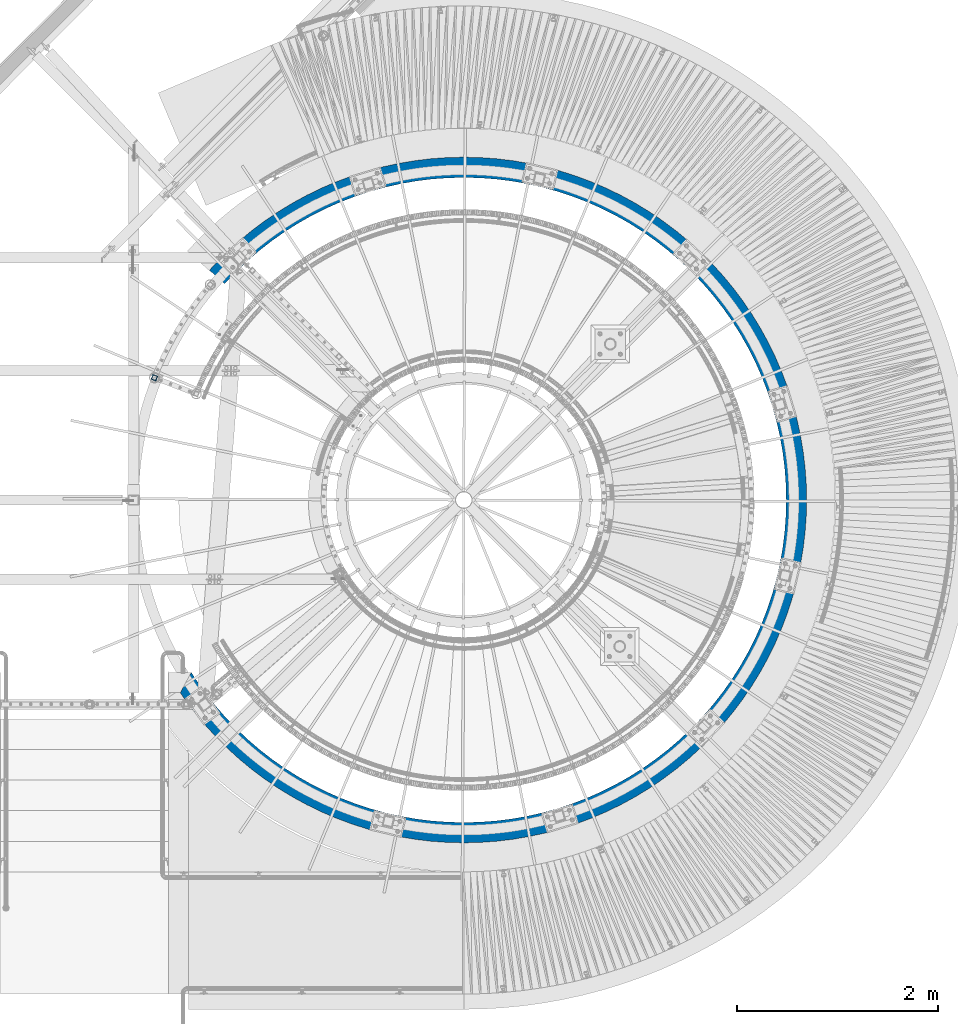
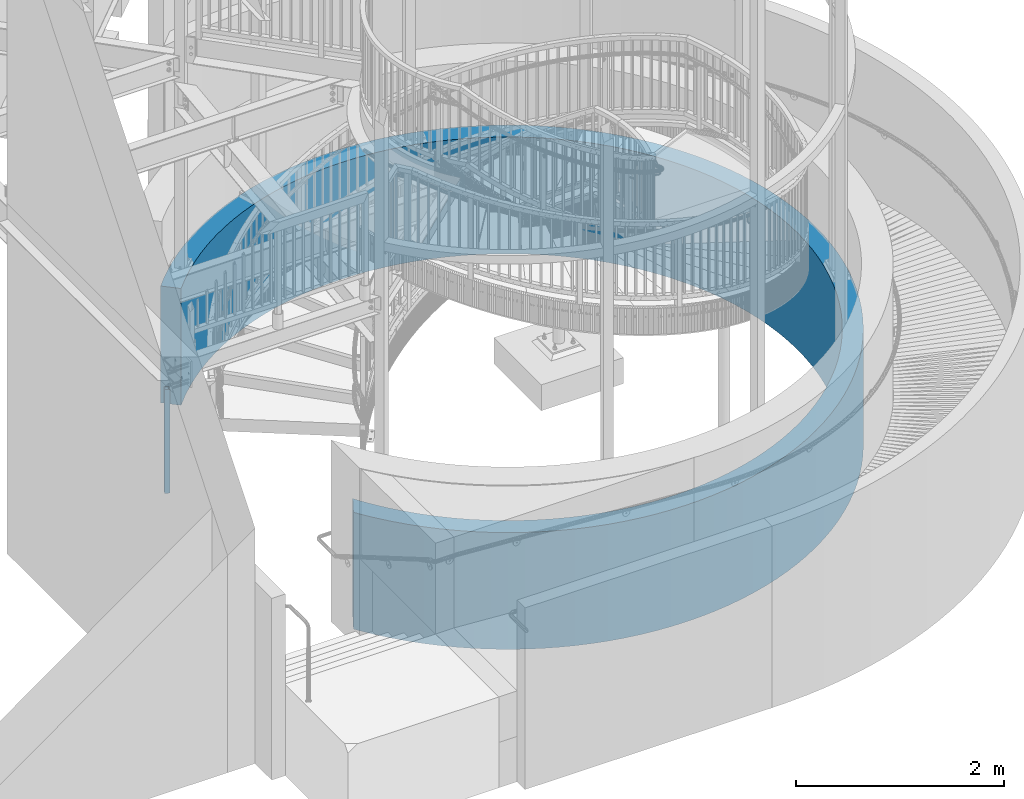
# One storey, part 133 of 975: 2 columns.
"""IFC2X3 building model written with IfcOpenShell, lengths in millimetres."""

from ifc_helpers import new_model, si_unit, frame, origin_with_axes, place, context, subcontext, project, spatial, faceted_brep, material, type_object, element, save


model = new_model("IFC2X3")

# Units and contexts
model_context = context("Model", 3, precision=1e-05, world=origin_with_axes())
body_context = subcontext(model_context, "Body", "Model", "MODEL_VIEW")
ifc_project = project(units=[si_unit("LENGTHUNIT", "METRE", prefix="MILLI"), si_unit("AREAUNIT", "SQUARE_METRE"), si_unit("VOLUMEUNIT", "CUBIC_METRE"), si_unit("MASSUNIT", "GRAM", prefix="KILO"), si_unit("TIMEUNIT", "SECOND"), si_unit("PLANEANGLEUNIT", "RADIAN"), si_unit("SOLIDANGLEUNIT", "STERADIAN"), si_unit("THERMODYNAMICTEMPERATUREUNIT", "DEGREE_CELSIUS"), si_unit("LUMINOUSINTENSITYUNIT", "LUMEN")], contexts=[model_context])

# Site, building, storey
site_placement = place(None, origin_with_axes())
site = spatial("IfcSite", under=ifc_project, at=site_placement, CompositionType="ELEMENT")
building_placement = place(site_placement, origin_with_axes())
building = spatial("IfcBuilding", under=site, at=building_placement, Name="Undefined", CompositionType="ELEMENT")
storey_placement = place(building_placement, origin_with_axes())
storey = spatial("IfcBuildingStorey", under=building, at=storey_placement, Name="Undefined", CompositionType="ELEMENT", Elevation=0.0)

# Columns
ifc_material_1 = material()
column_type_1 = type_object("IfcColumnType", Name="HSS2X2X.188_TUBES", PredefinedType="NOTDEFINED")
column_1_placement = place(storey_placement, frame((31648.9149123905, 4623.21435817273, -203.2), z_axis=(-0.929988356103301, 0.36758897904083, 0.0), x_axis=(0.0, 0.0, 1.0)))
element("IfcColumn", 1, at=column_1_placement, inside=storey, type_object=column_type_1, material=ifc_material_1, Name="HANDRAIL", ObjectType="HSS2X2X.188_TUBES", context=body_context, shape_type="Brep", body=[
    faceted_brep([(0.0, 20.6374999999753, -20.6375000000298), (0.0, -20.6375000000153, -20.6375000000153), (1219.2, -20.6374999999971, -20.6375000000298), (1219.2, 20.6374999999844, -20.6374999999716), (0.0, -20.6374999999825, 20.6375000000335), (1219.2, -20.6374999999898, 20.6374999999825), (0.0, 20.6375000000116, 20.6375000000189), (1219.2, 20.6374999999916, 20.6375000000407), (0.0, 25.3999999999724, -25.4000000000342), (0.0, 25.400000000016, 25.4000000000196), (1219.19999999993, 25.400000000016, 25.4000000000196), (1219.2, 25.3999999999814, -25.3999999999614), (0.0, -25.399999999976, 25.4000000000378), (1219.19999934962, -25.399999999976, 25.4000000000378), (0.0, -25.400000000016, -25.4000000000196), (1219.2, -25.399999999996, -25.4000000000378)], [[[0, 1, 2, 3]], [[1, 4, 5, 2]], [[4, 6, 7, 5]], [[6, 0, 3, 7]], [[8, 9, 10, 11]], [[9, 12, 13, 10]], [[12, 14, 15, 13]], [[14, 8, 11, 15]], [[13, 15, 11, 10], [5, 7, 3, 2]], [[14, 12, 9, 8], [6, 4, 1, 0]]]),
])
ifc_material_2 = material(Name="STEEL/Zero_Density")
column_type_2 = type_object("IfcColumnType", PredefinedType="NOTDEFINED")
column_2_placement = place(storey_placement, frame((34734.5, 3403.59999999999, -1.02318153949454e-12), z_axis=(0.0, 1.0, 0.0), x_axis=(0.0, 0.0, 1.0)))
element("IfcColumn", 2, at=column_2_placement, inside=storey, type_object=column_type_2, material=ifc_material_2, Name="WALL", context=body_context, shape_type="Brep", body=[
    faceted_brep([(1371.6, -2536.44157905321, 2291.88939873259), (-5.42101086242752e-20, -2536.44158720958, 2291.88938976323), (2.86308850465079e-05, -2386.29403404741, 2156.2183829727), (1371.6, -2386.29401758672, 2156.21838297135), (1371.6, -2383.10246661706, 2159.91827750059), (2.85925926453067e-05, -2383.10248307893, 2159.91827750059), (2.72865718446975e-05, -2274.24976503867, 2274.24986266076), (1371.6, -2274.24974857681, 2274.24986266076), (2.59148152999452e-05, -2159.9181798785, 2383.10258070102), (1371.6, -2159.91816341664, 2383.10258070102), (2.44806276927179e-05, -2040.38316240134, 2486.21419588924), (1371.6, -2040.38314593947, 2486.21419588924), (2.29874641065811e-05, -1915.93268293431, 2583.33630331291), (1371.6, -1915.93266647244, 2583.33630331291), (2.14389217033998e-05, -1786.86655358303, 2674.23492730837), (1371.6, -1786.86653712117, 2674.23492730837), (1.98387310574593e-05, -1653.49570595796, 2758.69108512862), (1371.6, -1653.4956894961, 2758.69108512862), (1.81907471681861e-05, -1516.14144211294, 2836.501314492), (1371.6, -1516.14142565108, 2836.501314492), (1.64989401731156e-05, -1375.13466050039, 2907.4781637406), (1371.6, -1375.13464403852, 2907.4781637406), (1.47673857834837e-05, -1230.81505880794, 2971.45064342774), (1371.6, -1230.81504234608, 2971.45064342774), (1.30002554654814e-05, -1083.53031559697, 3028.26463824652), (1371.6, -1083.53029913511, 3028.26463824652), (1.1201806390827e-05, -933.635252714506, 3077.78327830711), (1371.6, -933.635236252638, 3077.78327830711), (9.37637118086693e-06, -781.490980496281, 3119.88726886828), (1371.6, -781.490964034412, 3119.88726886828), (7.52834746891109e-06, -627.46402782033, 3154.4751777289), (1371.6, -627.464011358468, 3154.4751777289), (5.66218730594964e-06, -471.925459106831, 3181.46367958698), (1371.6, -471.925442644962, 3181.46367958698), (3.78238643527118e-06, -315.249980391367, 3200.78775677762), (1371.6, -315.249963929498, 3200.78775677762), (1.89347346182442e-06, -157.815036625325, 3212.40085590629), (1371.6, -157.815020163463, 3212.40085590629), (-1.05758831596761e-12, 9.76220908341929e-05, 3216.275), (1371.6, 0.000114083959488198, 3216.275), (-1.89347557700106e-06, 157.815231869507, 3212.40085590629), (1371.6, 157.815248331375, 3212.40085590629), (-3.78238855044781e-06, 315.250175635549, 3200.78775677762), (1371.6, 315.250192097417, 3200.78775677762), (-5.66218942112627e-06, 471.925654351013, 3181.46367958698), (1371.6, 471.925670812874, 3181.46367958698), (-7.52834958408772e-06, 627.464223064511, 3154.4751777289), (1371.6, 627.46423952638, 3154.4751777289), (-9.37637329604345e-06, 781.491175740462, 3119.88726886828), (1371.6, 781.491192202324, 3119.88726886828), (-1.12018085060036e-05, 933.635447958688, 3077.78327830711), (1371.6, 933.635464420549, 3077.78327830711), (-1.3000257580658e-05, 1083.53051084116, 3028.26463824652), (1371.6, 1083.53052730302, 3028.26463824652), (-1.47673878986603e-05, 1230.81525405212, 2971.45064342774), (1371.6, 1230.81527051399, 2971.45064342774), (-1.64989422882922e-05, 1375.13485574457, 2907.4781637406), (1371.6, 1375.13487220644, 2907.4781637406), (-1.81907492833627e-05, 1516.14163735713, 2836.50131449201), (1371.6, 1516.141653819, 2836.50131449201), (-1.98387331726359e-05, 1653.49590120214, 2758.69108512862), (1371.6, 1653.49591766401, 2758.69108512862), (-2.14389238185764e-05, 1786.86674882721, 2674.23492730837), (1371.6, 1786.86676528908, 2674.23492730837), (-2.29874662217577e-05, 1915.93287817849, 2583.33630331291), (1371.6, 1915.93289464035, 2583.33630331291), (-2.44806298078945e-05, 2040.38335764552, 2486.21419588924), (1371.6, 2040.38337410738, 2486.21419588924), (-2.59148174151219e-05, 2159.91837512269, 2383.10258070102), (1371.6, 2159.91839158455, 2383.10258070102), (-2.72865739598742e-05, 2274.24996028285, 2274.24986266076), (1371.6, 2274.24997674472, 2274.24986266076), (-2.85925947604833e-05, 2383.10267832311, 2159.91827750059), (1371.6, 2383.10269478498, 2159.91827750059), (-2.98297334984468e-05, 2486.21429351133, 2040.38326002343), (1371.6, 2486.21430997319, 2040.38326002343), (-3.09950097981842e-05, 2583.336400935, 1915.9327805564), (1371.6, 2583.33641739687, 1915.9327805564), (-3.20856164070234e-05, 2674.23502493046, 1786.86665120512), (1371.6, 2674.23504139233, 1786.86665120512), (-3.30989259581179e-05, 2758.69118275071, 1653.49580358005), (1371.6, 2758.69119921258, 1653.49580358005), (-3.40324973000035e-05, 2836.5014121141, 1516.14153973504), (1371.6, 2836.50142857596, 1516.14153973504), (-3.48840813775466e-05, 2907.4782613627, 1375.13475812248), (1371.6, 2907.47827782456, 1375.13475812248), (-3.56516266501143e-05, 2971.45074104983, 1230.81515643003), (1371.6, 2971.45075751169, 1230.81515643003), (-3.6333284033916e-05, 3028.26473586861, 1083.53041321906), (1371.6, 3028.26475233048, 1083.53041321906), (-3.69274113566081e-05, 3077.7833759292, 933.635350336596), (1371.6, 3077.78339239107, 933.635350336596), (-3.74325773134306e-05, 3119.88736649037, 781.491078118371), (1371.6, 3119.88738295224, 781.491078118371), (-3.78475649153464e-05, 3154.47527535099, 627.464125442424), (1371.6, 3154.47529181286, 627.464125442424), (-3.81713744208737e-05, 3181.46377720906, 471.925556728919), (1371.6, 3181.46379367093, 471.925556728919), (-3.84032257445515e-05, 3200.78785439971, 315.250078013458), (1371.6, 3200.78787086158, 315.250078013458), (-3.85425603362332e-05, 3212.40095352838, 157.815134247416), (1371.6, 3212.40096999025, 157.815134247416), (-3.85890425266831e-05, 3216.27509762209, 4.54747350886464e-13), (1371.6, 3216.27511408396, 4.54747350886464e-13), (-3.85425603362332e-05, 3212.40095352838, -157.815134247415), (1371.6, 3212.40096999025, -157.815134247415), (-3.84032257445515e-05, 3200.78785439971, -315.250078013457), (1371.6, 3200.78787086158, -315.250078013457), (-3.81713744208737e-05, 3181.46377720906, -471.925556728918), (1371.6, 3181.46379367093, -471.925556728918), (-3.78475649153464e-05, 3154.47527535099, -627.464125442423), (1371.6, 3154.47529181286, -627.464125442423), (-3.74325773134306e-05, 3119.88736649037, -781.49107811837), (1371.6, 3119.88738295224, -781.49107811837), (-3.69274113566081e-05, 3077.7833759292, -933.635350336595), (1371.6, 3077.78339239107, -933.635350336595), (-3.6333284033916e-05, 3028.26473586861, -1083.53041321906), (1371.6, 3028.26475233048, -1083.53041321906), (-3.56516266501143e-05, 2971.45074104983, -1230.81515643003), (1371.6, 2971.45075751169, -1230.81515643003), (-3.48840813775466e-05, 2907.4782613627, -1375.13475812248), (1371.6, 2907.47827782456, -1375.13475812248), (-3.40324973000035e-05, 2836.5014121141, -1516.14153973504), (1371.6, 2836.50142857596, -1516.14153973504), (-3.30989259581179e-05, 2758.69118275071, -1653.49580358005), (1371.6, 2758.69119921258, -1653.49580358005), (-3.20856164070234e-05, 2674.23502493046, -1786.86665120512), (1371.6, 2674.23504139233, -1786.86665120512), (-3.09950097981842e-05, 2583.336400935, -1915.9327805564), (1371.6, 2583.33641739687, -1915.9327805564), (-2.98297334984468e-05, 2486.21429351133, -2040.38326002343), (1371.6, 2486.2143099732, -2040.38326002343), (-2.85925947604833e-05, 2383.10267832311, -2159.91827750059), (1371.6, 2383.10269478498, -2159.91827750059), (-2.72865739598742e-05, 2274.24996028285, -2274.24986266076), (1371.6, 2274.24997674472, -2274.24986266076), (-2.59148174151219e-05, 2159.91837512269, -2383.10258070102), (1371.6, 2159.91839158455, -2383.10258070102), (-2.44806298078945e-05, 2040.38335764552, -2486.21419588924), (1371.6, 2040.38337410739, -2486.21419588924), (-2.29874662217577e-05, 1915.93287817849, -2583.33630331291), (1371.6, 1915.93289464035, -2583.33630331291), (-2.14389238185764e-05, 1786.86674882721, -2674.23492730837), (1371.6, 1786.86676528908, -2674.23492730837), (-1.98387331726359e-05, 1653.49590120214, -2758.69108512862), (1371.6, 1653.49591766401, -2758.69108512862), (-1.81907492833627e-05, 1516.14163735713, -2836.50131449201), (1371.6, 1516.141653819, -2836.50131449201), (-1.64989422882922e-05, 1375.13485574457, -2907.4781637406), (1371.6, 1375.13487220644, -2907.4781637406), (-1.47673878986603e-05, 1230.81525405212, -2971.45064342774), (1371.6, 1230.81527051399, -2971.45064342774), (-1.3000257580658e-05, 1083.53051084116, -3028.26463824652), (1371.6, 1083.53052730302, -3028.26463824652), (-1.12018085060036e-05, 933.635447958688, -3077.78327830711), (1371.6, 933.635464420549, -3077.78327830711), (-9.37637329604345e-06, 781.491175740462, -3119.88726886828), (1371.6, 781.491192202324, -3119.88726886828), (-7.52834958408778e-06, 627.464223064519, -3154.4751777289), (1371.6, 627.46423952638, -3154.4751777289), (-5.66218942112627e-06, 471.925654351013, -3181.46367958698), (1371.6, 471.925670812874, -3181.46367958698), (-3.78238855044781e-06, 315.250175635549, -3200.78775677762), (1371.6, 315.25019209741, -3200.78775677762), (-1.89347557700106e-06, 157.815231869507, -3212.40085590629), (1371.6, 157.815248331375, -3212.40085590629), (-1.05758831596761e-12, 9.76220908341929e-05, -3216.275), (1371.6, 0.000114083959488198, -3216.275), (1.89347346182442e-06, -157.815036625325, -3212.40085590629), (1371.6, -157.815020163456, -3212.40085590629), (3.78238643527118e-06, -315.249980391367, -3200.78775677762), (1371.6, -315.249963929498, -3200.78775677762), (5.66218730594964e-06, -471.925459106831, -3181.46367958698), (1371.6, -471.925442644962, -3181.46367958698), (7.52834746891109e-06, -627.46402782033, -3154.4751777289), (1371.6, -627.464011358468, -3154.4751777289), (9.37637118086687e-06, -781.490980496281, -3119.88726886828), (1371.6, -781.490964034412, -3119.88726886828), (1.1201806390827e-05, -933.635252714506, -3077.78327830711), (1371.6, -933.635236252638, -3077.78327830711), (1.30002554654814e-05, -1083.53031559697, -3028.26463824652), (1371.6, -1083.53029913511, -3028.26463824652), (1.47673857834837e-05, -1230.81505880794, -2971.45064342774), (1371.6, -1230.81504234608, -2971.45064342774), (1.64989401731156e-05, -1375.13466050039, -2907.4781637406), (1371.6, -1375.13464403852, -2907.4781637406), (1.81907471681861e-05, -1516.14144211294, -2836.50131449201), (1371.6, -1516.14142565108, -2836.50131449201), (1.98387310574593e-05, -1653.49570595796, -2758.69108512863), (1371.6, -1653.4956894961, -2758.69108512863), (2.14389217033998e-05, -1786.86655358303, -2674.23492730837), (1371.6, -1786.86653712116, -2674.23492730837), (2.29874641065811e-05, -1915.93268293431, -2583.33630331291), (1371.6, -1915.93266647244, -2583.33630331291), (2.44806276927179e-05, -2040.38316240134, -2486.21419588924), (1371.6, -2040.38314593947, -2486.21419588924), (2.59148152999452e-05, -2159.9181798785, -2383.10258070102), (1371.6, -2159.91816341664, -2383.10258070102), (2.72865718446975e-05, -2274.24976503867, -2274.24986266076), (1371.6, -2274.24974857681, -2274.24986266076), (2.85925926453067e-05, -2383.10248307893, -2159.9182775006), (1371.6, -2383.10246661706, -2159.9182775006), (2.98297313832701e-05, -2486.21409826714, -2040.38326002343), (1371.6, -2486.21408180528, -2040.38326002343), (3.09950076830076e-05, -2583.33620569082, -1915.9327805564), (1371.6, -2583.33618922895, -1915.9327805564), (3.20856142918468e-05, -2674.23482968628, -1786.86665120512), (1371.6, -2674.23481322441, -1786.86665120512), (3.26075235737852e-05, -2717.73432363227, -1718.17344364546), (1371.6, -2717.73430717184, -1718.17344364319), (-1.0842021724855e-19, -2827.3831652323, -1921.49268502268), (1371.6, -2827.38315607086, -1921.49269855475), (-1.62630325872826e-19, -2785.42210363731, -1983.49010085597), (1371.6, -2785.42210363465, -1983.49010085597), (-1.0842021724855e-19, -2687.88890614558, -2113.77919940671), (1371.6, -2687.88890614292, -2113.77919940671), (-1.0842021724855e-19, -2584.26677576502, -2239.27990820756), (1371.6, -2584.26677576235, -2239.27990820756), (-1.0842021724855e-19, -2474.79044994933, -2359.7079277878), (1371.6, -2474.79044994666, -2359.7079277878), (-1.62630325872826e-19, -2359.70792778779, -2474.79044994934), (1371.6, -2359.70792778512, -2474.79044994934), (-1.0842021724855e-19, -2239.27990820754, -2584.26677576503), (1371.6, -2239.27990820488, -2584.26677576503), (-1.0842021724855e-19, -2113.7791994067, -2687.88890614559), (1371.6, -2113.77919940403, -2687.88890614559), (-1.0842021724855e-19, -1983.49010085596, -2785.42210363732), (1371.6, -1983.4901008533, -2785.42210363732), (-1.62630325872826e-19, -1848.70775926897, -2876.6454241779), (1371.6, -1848.7077592663, -2876.6454241779), (-1.62630325872826e-19, -1709.73749999999, -2961.35221760579), (1371.6, -1709.73749999733, -2961.35221760579), (-1.0842021724855e-19, -1566.89413538383, -3039.35059578929), (1371.6, -1566.89413538116, -3039.35059578929), (-1.0842021724855e-19, -1420.50125158462, -3110.46386731489), (1371.6, -1420.50125158195, -3110.46386731489), (-1.0842021724855e-19, -1270.89047556909, -3174.53093775014), (1371.6, -1270.89047556642, -3174.53093775014), (-1.0842021724855e-19, -1118.40072386483, -3231.40667457434), (1371.6, -1118.40072386216, -3231.40667457434), (-1.0842021724855e-19, -963.377434805341, -3280.96223595043), (1371.6, -963.377434802671, -3280.96223595043), (-5.42101086242752e-20, -806.17178600109, -3323.08536259314), (1371.6, -806.17178599842, -3323.08536259314), (-1.0842021724855e-19, -647.139898809306, -3357.68063207239), (1371.6, -647.139898806636, -3357.68063207239), (-1.0842021724855e-19, -486.642031604533, -3384.6696749758), (1371.6, -486.642031601863, -3384.6696749758), (-1.0842021724855e-19, -325.04176367756, -3403.9913524406), (1371.6, -325.041763674897, -3403.9913524406), (-1.0842021724855e-19, -162.705171611386, -3415.60189465282), (1371.6, -162.705171608715, -3415.60189465282), (-1.0842021724855e-19, 7.27595761418343e-12, -3419.475), (1371.6, 2.6775524020195e-09, -3419.475), (-1.0842021724855e-19, 162.7051716114, -3415.60189465282), (1371.6, 162.70517161407, -3415.60189465282), (-1.62630325872826e-19, 325.041763677582, -3403.9913524406), (1371.6, 325.041763680245, -3403.9913524406), (-5.42101086242752e-20, 486.642031604548, -3384.6696749758), (1371.6, 486.642031607218, -3384.6696749758), (-1.0842021724855e-19, 647.139898809321, -3357.68063207239), (1371.6, 647.139898811991, -3357.68063207239), (-1.0842021724855e-19, 806.171786001105, -3323.08536259314), (1371.6, 806.171786003775, -3323.08536259314), (-1.0842021724855e-19, 963.377434805356, -3280.96223595043), (1371.6, 963.377434808026, -3280.96223595043), (-1.0842021724855e-19, 1118.40072386485, -3231.40667457434), (1371.6, 1118.40072386752, -3231.40667457434), (-5.42101086242752e-20, 1270.8904755691, -3174.53093775013), (1371.6, 1270.89047557177, -3174.53093775013), (-1.0842021724855e-19, 1420.50125158463, -3110.46386731489), (1371.6, 1420.5012515873, -3110.46386731489), (-1.0842021724855e-19, 1566.89413538385, -3039.35059578929), (1371.6, 1566.89413538651, -3039.35059578929), (-1.0842021724855e-19, 1709.73750000001, -2961.35221760579), (1371.6, 1709.73750000267, -2961.35221760579), (-1.0842021724855e-19, 1848.70775926899, -2876.6454241779), (1371.6, 1848.70775927166, -2876.6454241779), (-1.62630325872826e-19, 1983.49010085598, -2785.42210363732), (1371.6, 1983.49010085865, -2785.42210363732), (-5.42101086242752e-20, 2113.77919940671, -2687.88890614559), (1371.6, 2113.77919940938, -2687.88890614559), (-1.0842021724855e-19, 2239.27990820756, -2584.26677576503), (1371.6, 2239.27990821023, -2584.26677576503), (-5.42101086242752e-20, 2359.7079277878, -2474.79044994933), (1371.6, 2359.70792779047, -2474.79044994933), (-1.62630325872826e-19, 2474.79044994935, -2359.70792778779), (1371.6, 2474.79044995201, -2359.70792778779), (-5.42101086242752e-20, 2584.26677576503, -2239.27990820755), (1371.6, 2584.2667757677, -2239.27990820755), (-1.0842021724855e-19, 2687.8889061456, -2113.7791994067), (1371.6, 2687.88890614827, -2113.7791994067), (-5.42101086242752e-20, 2785.42210363733, -1983.49010085597), (1371.6, 2785.42210364, -1983.49010085597), (-1.0842021724855e-19, 2876.64542417791, -1848.70775926898), (1371.6, 2876.64542418058, -1848.70775926898), (-1.0842021724855e-19, 2961.3522176058, -1709.7375), (1371.6, 2961.35221760847, -1709.7375), (-1.0842021724855e-19, 3039.3505957893, -1566.89413538384), (1371.6, 3039.35059579197, -1566.89413538384), (-1.62630325872826e-19, 3110.4638673149, -1420.50125158462), (1371.6, 3110.46386731757, -1420.50125158462), (-5.42101086242752e-20, 3174.53093775014, -1270.8904755691), (1371.6, 3174.53093775281, -1270.8904755691), (-5.42101086242752e-20, 3231.40667457435, -1118.40072386484), (1371.6, 3231.40667457702, -1118.40072386484), (-1.0842021724855e-19, 3280.96223595044, -963.377434805347), (1371.6, 3280.96223595311, -963.377434805347), (-1.0842021724855e-19, 3323.08536259315, -806.171786001098), (1371.6, 3323.08536259582, -806.171786001098), (-1.0842021724855e-19, 3357.6806320724, -647.139898809312), (1371.6, 3357.68063207507, -647.139898809312), (-1.0842021724855e-19, 3384.66967497581, -486.642031604541), (1371.6, 3384.66967497848, -486.642031604541), (-1.0842021724855e-19, 3403.99135244061, -325.04176367757), (1371.6, 3403.99135244327, -325.04176367757), (-5.42101086242752e-20, 3415.60189465282, -162.70517161139), (1371.6, 3415.60189465549, -162.70517161139), (-1.0842021724855e-19, 3419.47500000001, 4.54747350886464e-13), (1371.6, 3419.47500000268, 4.54747350886464e-13), (-5.42101086242752e-20, 3415.60189465282, 162.705171611392), (1371.6, 3415.60189465549, 162.705171611392), (-1.0842021724855e-19, 3403.99135244061, 325.041763677571), (1371.6, 3403.99135244327, 325.041763677571), (-1.0842021724855e-19, 3384.66967497581, 486.642031604542), (1371.6, 3384.66967497848, 486.642031604542), (-1.0842021724855e-19, 3357.6806320724, 647.139898809315), (1371.6, 3357.68063207507, 647.139898809315), (-1.0842021724855e-19, 3323.08536259315, 806.171786001099), (1371.6, 3323.08536259582, 806.171786001099), (-1.0842021724855e-19, 3280.96223595044, 963.377434805349), (1371.6, 3280.96223595311, 963.377434805349), (-5.42101086242752e-20, 3231.40667457435, 1118.40072386484), (1371.6, 3231.40667457702, 1118.40072386484), (-5.42101086242752e-20, 3174.53093775014, 1270.8904755691), (1371.6, 3174.53093775281, 1270.8904755691), (-1.62630325872826e-19, 3110.4638673149, 1420.50125158463), (1371.6, 3110.46386731757, 1420.50125158463), (-1.0842021724855e-19, 3039.3505957893, 1566.89413538384), (1371.6, 3039.35059579197, 1566.89413538384), (-1.62630325872826e-19, 2961.3522176058, 1709.7375), (1371.6, 2961.35221760847, 1709.7375), (-1.62630325872826e-19, 2876.64542417791, 1848.70775926898), (1371.6, 2876.64542418058, 1848.70775926898), (-5.42101086242752e-20, 2785.42210363733, 1983.49010085597), (1371.6, 2785.42210364, 1983.49010085597), (-1.0842021724855e-19, 2687.8889061456, 2113.7791994067), (1371.6, 2687.88890614827, 2113.7791994067), (-5.42101086242752e-20, 2584.26677576503, 2239.27990820755), (1371.6, 2584.2667757677, 2239.27990820755), (-1.62630325872826e-19, 2474.79044994935, 2359.70792778779), (1371.6, 2474.79044995201, 2359.70792778779), (-5.42101086242752e-20, 2359.7079277878, 2474.79044994934), (1371.6, 2359.70792779047, 2474.79044994934), (-1.0842021724855e-19, 2239.27990820756, 2584.26677576503), (1371.6, 2239.27990821023, 2584.26677576503), (-5.42101086242752e-20, 2113.77919940671, 2687.88890614559), (1371.6, 2113.77919940938, 2687.88890614559), (-1.62630325872826e-19, 1983.49010085598, 2785.42210363732), (1371.6, 1983.49010085865, 2785.42210363732), (-1.62630325872826e-19, 1848.70775926899, 2876.6454241779), (1371.6, 1848.70775927165, 2876.6454241779), (-5.42101086242752e-20, 1709.7375, 2961.35221760579), (1371.6, 1709.73750000267, 2961.35221760579), (-1.0842021724855e-19, 1566.89413538385, 3039.35059578929), (1371.6, 1566.89413538651, 3039.35059578929), (-1.0842021724855e-19, 1420.50125158463, 3110.46386731489), (1371.6, 1420.5012515873, 3110.46386731489), (-1.0842021724855e-19, 1270.8904755691, 3174.53093775013), (1371.6, 1270.89047557177, 3174.53093775013), (-1.0842021724855e-19, 1118.40072386485, 3231.40667457434), (1371.6, 1118.40072386751, 3231.40667457434), (-1.0842021724855e-19, 963.377434805356, 3280.96223595043), (1371.6, 963.377434808019, 3280.96223595043), (-1.0842021724855e-19, 806.171786001105, 3323.08536259314), (1371.6, 806.171786003775, 3323.08536259314), (-1.0842021724855e-19, 647.139898809321, 3357.68063207239), (1371.6, 647.139898811991, 3357.68063207239), (-5.42101086242752e-20, 486.642031604548, 3384.6696749758), (1371.6, 486.642031607218, 3384.6696749758), (-5.42101086242752e-20, 325.041763677575, 3403.9913524406), (1371.6, 325.041763680245, 3403.9913524406), (-1.0842021724855e-19, 162.7051716114, 3415.60189465282), (1371.6, 162.705171614063, 3415.60189465282), (-1.0842021724855e-19, 7.27595761418343e-12, 3419.475), (1371.6, 2.6775524020195e-09, 3419.475), (-1.0842021724855e-19, -162.705171611386, 3415.60189465282), (1371.6, -162.705171608715, 3415.60189465282), (-1.62630325872826e-19, -325.04176367756, 3403.9913524406), (1371.6, -325.041763674897, 3403.9913524406), (-1.62630325872826e-19, -486.642031604533, 3384.6696749758), (1371.6, -486.64203160187, 3384.6696749758), (-1.0842021724855e-19, -647.139898809306, 3357.68063207239), (1371.6, -647.139898806636, 3357.68063207239), (-1.0842021724855e-19, -806.17178600109, 3323.08536259314), (1371.6, -806.171785998427, 3323.08536259314), (-1.0842021724855e-19, -963.377434805341, 3280.96223595043), (1371.6, -963.377434802671, 3280.96223595043), (-1.0842021724855e-19, -1118.40072386483, 3231.40667457434), (1371.6, -1118.40072386216, 3231.40667457434), (-1.62630325872826e-19, -1270.89047556909, 3174.53093775013), (1371.6, -1270.89047556643, 3174.53093775013), (-1.0842021724855e-19, -1420.50125158462, 3110.46386731489), (1371.6, -1420.50125158195, 3110.46386731489), (-1.0842021724855e-19, -1566.89413538383, 3039.35059578929), (1371.6, -1566.89413538116, 3039.35059578929), (-1.0842021724855e-19, -1709.7375, 2961.35221760579), (1371.6, -1709.73749999733, 2961.35221760579), (-5.42101086242752e-20, -1848.70775926897, 2876.6454241779), (1371.6, -1848.7077592663, 2876.6454241779), (-1.0842021724855e-19, -1983.49010085596, 2785.42210363732), (1371.6, -1983.4901008533, 2785.42210363732), (-1.0842021724855e-19, -2113.7791994067, 2687.88890614559), (1371.6, -2113.77919940403, 2687.88890614559), (-1.0842021724855e-19, -2239.27990820755, 2584.26677576503), (1371.6, -2239.27990820488, 2584.26677576503), (-1.0842021724855e-19, -2359.70792778779, 2474.79044994933), (1371.6, -2359.70792778512, 2474.79044994933), (-1.0842021724855e-19, -2474.79044994933, 2359.70792778779), (1371.6, -2474.79044994666, 2359.70792778779)], [[[0, 1, 2, 3]], [[4, 5, 6, 7]], [[7, 6, 8, 9]], [[9, 8, 10, 11]], [[11, 10, 12, 13]], [[13, 12, 14, 15]], [[15, 14, 16, 17]], [[17, 16, 18, 19]], [[19, 18, 20, 21]], [[21, 20, 22, 23]], [[23, 22, 24, 25]], [[25, 24, 26, 27]], [[27, 26, 28, 29]], [[29, 28, 30, 31]], [[31, 30, 32, 33]], [[33, 32, 34, 35]], [[35, 34, 36, 37]], [[37, 36, 38, 39]], [[39, 38, 40, 41]], [[41, 40, 42, 43]], [[43, 42, 44, 45]], [[45, 44, 46, 47]], [[47, 46, 48, 49]], [[49, 48, 50, 51]], [[51, 50, 52, 53]], [[53, 52, 54, 55]], [[55, 54, 56, 57]], [[57, 56, 58, 59]], [[59, 58, 60, 61]], [[61, 60, 62, 63]], [[63, 62, 64, 65]], [[65, 64, 66, 67]], [[67, 66, 68, 69]], [[69, 68, 70, 71]], [[71, 70, 72, 73]], [[73, 72, 74, 75]], [[75, 74, 76, 77]], [[77, 76, 78, 79]], [[79, 78, 80, 81]], [[81, 80, 82, 83]], [[83, 82, 84, 85]], [[85, 84, 86, 87]], [[87, 86, 88, 89]], [[89, 88, 90, 91]], [[91, 90, 92, 93]], [[93, 92, 94, 95]], [[95, 94, 96, 97]], [[97, 96, 98, 99]], [[99, 98, 100, 101]], [[101, 100, 102, 103]], [[103, 102, 104, 105]], [[105, 104, 106, 107]], [[107, 106, 108, 109]], [[109, 108, 110, 111]], [[111, 110, 112, 113]], [[113, 112, 114, 115]], [[115, 114, 116, 117]], [[117, 116, 118, 119]], [[119, 118, 120, 121]], [[121, 120, 122, 123]], [[123, 122, 124, 125]], [[125, 124, 126, 127]], [[127, 126, 128, 129]], [[129, 128, 130, 131]], [[131, 130, 132, 133]], [[133, 132, 134, 135]], [[135, 134, 136, 137]], [[137, 136, 138, 139]], [[139, 138, 140, 141]], [[141, 140, 142, 143]], [[143, 142, 144, 145]], [[145, 144, 146, 147]], [[147, 146, 148, 149]], [[149, 148, 150, 151]], [[151, 150, 152, 153]], [[153, 152, 154, 155]], [[155, 154, 156, 157]], [[157, 156, 158, 159]], [[159, 158, 160, 161]], [[161, 160, 162, 163]], [[163, 162, 164, 165]], [[165, 164, 166, 167]], [[167, 166, 168, 169]], [[169, 168, 170, 171]], [[171, 170, 172, 173]], [[173, 172, 174, 175]], [[175, 174, 176, 177]], [[177, 176, 178, 179]], [[179, 178, 180, 181]], [[181, 180, 182, 183]], [[183, 182, 184, 185]], [[185, 184, 186, 187]], [[187, 186, 188, 189]], [[189, 188, 190, 191]], [[191, 190, 192, 193]], [[193, 192, 194, 195]], [[195, 194, 196, 197]], [[197, 196, 198, 199]], [[199, 198, 200, 201]], [[201, 200, 202, 203]], [[203, 202, 204, 205]], [[205, 204, 206, 207]], [[207, 206, 208, 209]], [[209, 208, 210, 211]], [[212, 213, 211, 210]], [[212, 214, 215, 213]], [[214, 216, 217, 215]], [[216, 218, 219, 217]], [[218, 220, 221, 219]], [[220, 222, 223, 221]], [[222, 224, 225, 223]], [[224, 226, 227, 225]], [[226, 228, 229, 227]], [[228, 230, 231, 229]], [[230, 232, 233, 231]], [[232, 234, 235, 233]], [[234, 236, 237, 235]], [[236, 238, 239, 237]], [[238, 240, 241, 239]], [[240, 242, 243, 241]], [[242, 244, 245, 243]], [[244, 246, 247, 245]], [[246, 248, 249, 247]], [[248, 250, 251, 249]], [[250, 252, 253, 251]], [[252, 254, 255, 253]], [[254, 256, 257, 255]], [[256, 258, 259, 257]], [[258, 260, 261, 259]], [[260, 262, 263, 261]], [[262, 264, 265, 263]], [[264, 266, 267, 265]], [[266, 268, 269, 267]], [[268, 270, 271, 269]], [[270, 272, 273, 271]], [[272, 274, 275, 273]], [[274, 276, 277, 275]], [[276, 278, 279, 277]], [[278, 280, 281, 279]], [[280, 282, 283, 281]], [[282, 284, 285, 283]], [[284, 286, 287, 285]], [[286, 288, 289, 287]], [[288, 290, 291, 289]], [[290, 292, 293, 291]], [[292, 294, 295, 293]], [[294, 296, 297, 295]], [[296, 298, 299, 297]], [[298, 300, 301, 299]], [[300, 302, 303, 301]], [[302, 304, 305, 303]], [[304, 306, 307, 305]], [[306, 308, 309, 307]], [[308, 310, 311, 309]], [[310, 312, 313, 311]], [[312, 314, 315, 313]], [[314, 316, 317, 315]], [[316, 318, 319, 317]], [[318, 320, 321, 319]], [[320, 322, 323, 321]], [[322, 324, 325, 323]], [[324, 326, 327, 325]], [[326, 328, 329, 327]], [[328, 330, 331, 329]], [[330, 332, 333, 331]], [[332, 334, 335, 333]], [[334, 336, 337, 335]], [[336, 338, 339, 337]], [[338, 340, 341, 339]], [[340, 342, 343, 341]], [[342, 344, 345, 343]], [[344, 346, 347, 345]], [[346, 348, 349, 347]], [[348, 350, 351, 349]], [[350, 352, 353, 351]], [[352, 354, 355, 353]], [[354, 356, 357, 355]], [[356, 358, 359, 357]], [[358, 360, 361, 359]], [[360, 362, 363, 361]], [[362, 364, 365, 363]], [[364, 366, 367, 365]], [[366, 368, 369, 367]], [[368, 370, 371, 369]], [[370, 372, 373, 371]], [[372, 374, 375, 373]], [[374, 376, 377, 375]], [[376, 378, 379, 377]], [[378, 380, 381, 379]], [[380, 382, 383, 381]], [[382, 384, 385, 383]], [[384, 386, 387, 385]], [[386, 388, 389, 387]], [[388, 390, 391, 389]], [[390, 392, 393, 391]], [[392, 394, 395, 393]], [[394, 396, 397, 395]], [[396, 398, 399, 397]], [[398, 400, 401, 399]], [[400, 402, 403, 401]], [[402, 404, 405, 403]], [[404, 406, 407, 405]], [[406, 408, 409, 407]], [[408, 410, 411, 409]], [[410, 412, 413, 411]], [[412, 414, 415, 413]], [[414, 416, 417, 415]], [[416, 418, 419, 417]], [[4, 7, 9, 11, 13, 15, 17, 19, 21, 23, 25, 27, 29, 31, 33, 35, 37, 39, 41, 43, 45, 47, 49, 51, 53, 55, 57, 59, 61, 63, 65, 67, 69, 71, 73, 75, 77, 79, 81, 83, 85, 87, 89, 91, 93, 95, 97, 99, 101, 103, 105, 107, 109, 111, 113, 115, 117, 119, 121, 123, 125, 127, 129, 131, 133, 135, 137, 139, 141, 143, 145, 147, 149, 151, 153, 155, 157, 159, 161, 163, 165, 167, 169, 171, 173, 175, 177, 179, 181, 183, 185, 187, 189, 191, 193, 195, 197, 199, 201, 203, 205, 207, 209, 211, 213, 215, 217, 219, 221, 223, 225, 227, 229, 231, 233, 235, 237, 239, 241, 243, 245, 247, 249, 251, 253, 255, 257, 259, 261, 263, 265, 267, 269, 271, 273, 275, 277, 279, 281, 283, 285, 287, 289, 291, 293, 295, 297, 299, 301, 303, 305, 307, 309, 311, 313, 315, 317, 319, 321, 323, 325, 327, 329, 331, 333, 335, 337, 339, 341, 343, 345, 347, 349, 351, 353, 355, 357, 359, 361, 363, 365, 367, 369, 371, 373, 375, 377, 379, 381, 383, 385, 387, 389, 391, 393, 395, 397, 399, 401, 403, 405, 407, 409, 411, 413, 415, 417, 419, 0, 3]], [[5, 4, 3, 2]], [[418, 416, 414, 412, 410, 408, 406, 404, 402, 400, 398, 396, 394, 392, 390, 388, 386, 384, 382, 380, 378, 376, 374, 372, 370, 368, 366, 364, 362, 360, 358, 356, 354, 352, 350, 348, 346, 344, 342, 340, 338, 336, 334, 332, 330, 328, 326, 324, 322, 320, 318, 316, 314, 312, 310, 308, 306, 304, 302, 300, 298, 296, 294, 292, 290, 288, 286, 284, 282, 280, 278, 276, 274, 272, 270, 268, 266, 264, 262, 260, 258, 256, 254, 252, 250, 248, 246, 244, 242, 240, 238, 236, 234, 232, 230, 228, 226, 224, 222, 220, 218, 216, 214, 212, 210, 208, 206, 204, 202, 200, 198, 196, 194, 192, 190, 188, 186, 184, 182, 180, 178, 176, 174, 172, 170, 168, 166, 164, 162, 160, 158, 156, 154, 152, 150, 148, 146, 144, 142, 140, 138, 136, 134, 132, 130, 128, 126, 124, 122, 120, 118, 116, 114, 112, 110, 108, 106, 104, 102, 100, 98, 96, 94, 92, 90, 88, 86, 84, 82, 80, 78, 76, 74, 72, 70, 68, 66, 64, 62, 60, 58, 56, 54, 52, 50, 48, 46, 44, 42, 40, 38, 36, 34, 32, 30, 28, 26, 24, 22, 20, 18, 16, 14, 12, 10, 8, 6, 5, 2, 1]], [[419, 418, 1, 0]]]),
])

save(model, "model.ifc")
